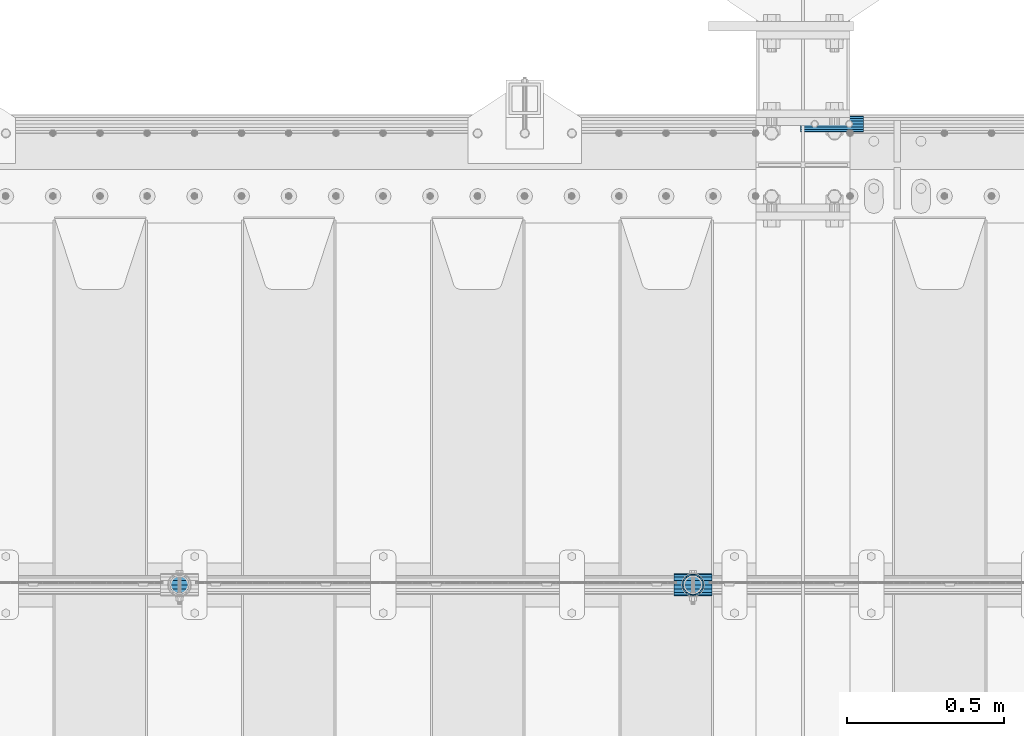
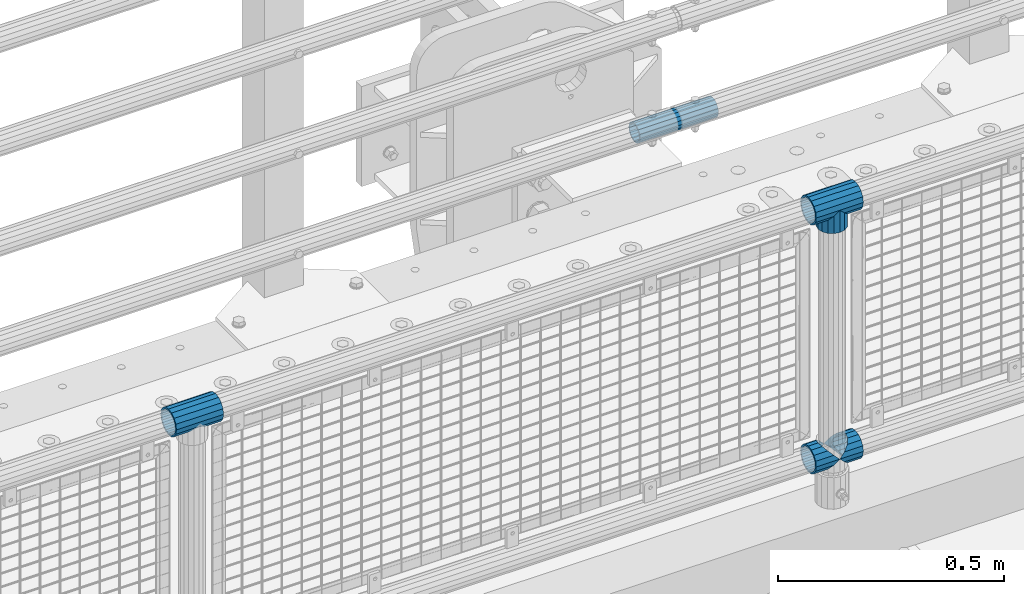
# One storey, part 169 of 270: 6 beams.
"""IFC2X3 building model written with IfcOpenShell, lengths in millimetres."""

from ifc_helpers import new_model, si_unit, frame, origin_with_axes, place, context, subcontext, project, spatial, faceted_brep, material, type_object, element, save


model = new_model("IFC2X3")

# Units and contexts
model_context = context("Model", 3, precision=1e-05, world=origin_with_axes())
body_context = subcontext(model_context, "Body", "Model", "MODEL_VIEW")
ifc_project = project(units=[si_unit("LENGTHUNIT", "METRE", prefix="MILLI"), si_unit("AREAUNIT", "SQUARE_METRE"), si_unit("VOLUMEUNIT", "CUBIC_METRE"), si_unit("MASSUNIT", "GRAM", prefix="KILO"), si_unit("TIMEUNIT", "SECOND"), si_unit("PLANEANGLEUNIT", "RADIAN"), si_unit("SOLIDANGLEUNIT", "STERADIAN"), si_unit("THERMODYNAMICTEMPERATUREUNIT", "DEGREE_CELSIUS"), si_unit("LUMINOUSINTENSITYUNIT", "LUMEN")], contexts=[model_context])

# Site, building, storey
site_placement = place(None, origin_with_axes())
site = spatial("IfcSite", under=ifc_project, at=site_placement, CompositionType="ELEMENT")
building_placement = place(site_placement, origin_with_axes())
building = spatial("IfcBuilding", under=site, at=building_placement, Name="Standard", CompositionType="ELEMENT")
storey_placement = place(building_placement, origin_with_axes())
storey = spatial("IfcBuildingStorey", under=building, at=storey_placement, Name="Undefined", CompositionType="ELEMENT", Elevation=0.0)

# Beams
ifc_material_1 = material(Name="Misc_Undefined")
beam_type_1 = type_object("IfcBeamType", PredefinedType="NOTDEFINED")
beam_1_placement = place(storey_placement, frame((13624.85, -16335.5, 298.17), z_axis=(0.0, 1.0, 0.0), x_axis=(1.0, 0.0, 0.0)))
element("IfcBeam", 1, at=beam_1_placement, inside=storey, type_object=beam_type_1, material=ifc_material_1, context=body_context, shape_type="Brep", body=[
    faceted_brep([(60.1499999999978, 0.0, -35.1499999999996), (46.698677352364, 13.4513226476329, -32.4743655677721), (46.698677352364, -13.4513226476329, -32.4743655677721), (33.0273231408937, 21.4606908090117, 21.4606908090118), (27.6756344322275, 26.8123795176776, 13.4513226476338), (27.6756344322275, 32.4743655677717, 13.4513226476338), (35.2951966412911, 24.8548033587072, 24.8548033587067), (35.2951966412911, 16.3810424080045, 24.8548033587067), (27.310256188277, 28.0397438117175, 11.6144421722802), (24.9999999999964, 30.35, 0.0), (24.9999999999964, 35.15, 0.0), (27.6756344322275, 26.8123795176775, -13.4513226476338), (27.6756344322275, 32.4743655677717, -13.4513226476338), (27.310256188277, 28.0397438117175, -11.6144421722802), (35.2951966412911, 16.3810424080045, -24.8548033587067), (35.2951966412911, 24.8548033587072, -24.8548033587067), (33.0273231408937, 21.4606908090117, -21.4606908090118), (40.0617968770166, 11.6144421722805, -28.0397438117179), (43.519339601633, 0.0, -30.3500000000004), (40.0617968770166, -11.6144421722805, -28.0397438117179), (35.2951966412911, -16.3810424080045, -24.8548033587067), (35.2951966412911, -24.8548033587072, -24.8548033587067), (33.0273231408937, -21.4606908090117, -21.4606908090118), (27.6756344322275, -26.8123795176776, -13.4513226476338), (27.6756344322275, -32.4743655677717, -13.4513226476338), (27.310256188277, -28.0397438117175, -11.6144421722802), (24.9999999999964, -30.35, 0.0), (24.9999999999964, -35.15, 0.0), (27.310256188277, -28.0397438117175, 11.6144421722802), (27.6756344322275, -26.8123795176775, 13.4513226476338), (27.6756344322275, -32.4743655677717, 13.4513226476338), (33.0273231408937, -21.4606908090117, 21.4606908090118), (35.2951966412911, -16.3810424080078, 24.8548033587067), (35.2951966412911, -24.8548033587072, 24.8548033587067), (60.1499999999978, 0.0, 35.1499999999996), (46.698677352364, -13.4513226476329, 32.4743655677721), (46.698677352364, 13.4513226476329, 32.4743655677721), (40.061796877013, -11.6144421722805, 28.0397438117179), (43.5193396016293, 0.0, 30.3500000000004), (40.061796877013, 11.6144421722805, 28.0397438117179), (0.0, -32.4743655677721, -13.4513226476338), (0.0, -24.8548033587067, -24.8548033587067), (0.0, -13.4513226476338, -32.4743655677703), (0.0, 0.0, -35.1499999999996), (0.0, 13.4513226476338, -32.4743655677703), (0.0, 24.8548033587067, -24.8548033587067), (0.0, 32.4743655677721, -13.4513226476338), (0.0, 35.1499999999996, 0.0), (0.0, 32.4743655677721, 13.4513226476338), (0.0, 24.8548033587067, 24.8548033587067), (0.0, 13.4513226476338, 32.4743655677703), (0.0, 0.0, 35.1499999999996), (0.0, -32.4743655677721, 13.4513226476338), (0.0, -35.1499999999996, 0.0), (0.0, -24.8548033587067, 24.8548033587067), (0.0, -13.4513226476338, 32.4743655677703), (0.0, -28.0397438117179, -11.614442172282), (0.0, -21.4606908090118, -21.46069080901), (0.0, -11.6144421722802, -28.0397438117179), (0.0, 0.0, -30.3499999999985), (0.0, 11.6144421722802, -28.0397438117179), (0.0, 21.4606908090118, -21.46069080901), (0.0, 28.0397438117179, -11.614442172282), (0.0, 30.3500000000004, 0.0), (0.0, 28.0397438117179, 11.614442172282), (0.0, 21.4606908090118, 21.46069080901), (0.0, 11.6144421722802, 28.0397438117179), (0.0, 0.0, 30.3499999999985), (0.0, -11.6144421722802, 28.0397438117179), (0.0, -21.4606908090118, 21.46069080901), (0.0, -28.0397438117179, 11.614442172282), (0.0, -30.3500000000004, 0.0)], [[[0, 1, 2]], [[3, 4, 5, 6, 7]], [[8, 9, 10, 5, 4]], [[11, 12, 10, 9, 13]], [[14, 15, 12, 11, 16]], [[2, 1, 15, 14, 17, 18, 19, 20, 21]], [[21, 20, 22, 23, 24]], [[24, 23, 25, 26, 27]], [[27, 26, 28, 29, 30]], [[30, 29, 31, 32, 33]], [[34, 35, 36]], [[33, 32, 37, 38, 39, 7, 6, 36, 35]], [[40, 41, 21, 24]], [[41, 42, 2, 21]], [[42, 43, 0, 2]], [[43, 44, 1, 0]], [[44, 45, 15, 1]], [[45, 46, 12, 15]], [[46, 47, 10, 12]], [[47, 48, 5, 10]], [[48, 49, 6, 5]], [[49, 50, 36, 6]], [[50, 51, 34, 36]], [[52, 53, 27, 30]], [[54, 52, 30, 33]], [[55, 54, 33, 35]], [[51, 55, 35, 34]], [[53, 40, 24, 27]], [[52, 54, 55, 51, 50, 49, 48, 47, 46, 45, 44, 43, 42, 41, 40, 53], [56, 57, 58, 59, 60, 61, 62, 63, 64, 65, 66, 67, 68, 69, 70, 71]], [[68, 67, 38, 37]], [[31, 69, 68, 37, 32]], [[28, 70, 69, 31, 29]], [[71, 70, 28, 26]], [[56, 71, 26, 25]], [[57, 56, 25, 23, 22]], [[58, 57, 22, 20, 19]], [[59, 58, 19, 18]], [[60, 59, 18, 17]], [[16, 61, 60, 17, 14]], [[13, 62, 61, 16, 11]], [[63, 62, 13, 9]], [[64, 63, 9, 8]], [[65, 64, 8, 4, 3]], [[66, 65, 3, 7, 39]], [[67, 66, 39, 38]]]),
])
beam_2_placement = place(storey_placement, frame((13685.0, -16335.5, 298.17), z_axis=(0.0, 1.0, 0.0), x_axis=(1.0, 0.0, 0.0)))
element("IfcBeam", 2, at=beam_2_placement, inside=storey, type_object=beam_type_1, material=ifc_material_1, context=body_context, shape_type="Brep", body=[
    faceted_brep([(13.4513226476338, 13.4513226476329, 32.4743655677721), (13.4513226476338, -13.4513226476329, 32.4743655677721), (0.0, 0.0, 35.1499999999996), (27.1226768591041, -21.4606908090117, -21.4606908090118), (24.8548033587067, -16.3810424080045, -24.8548033587067), (24.8548033587067, -24.8548033587072, -24.8548033587067), (32.4743655677703, -32.4743655677717, -13.4513226476338), (32.4743655677703, -26.8123795176776, -13.4513226476338), (0.0, 0.0, -35.1499999999996), (13.4513226476338, -13.4513226476329, -32.4743655677721), (13.4513226476338, 13.4513226476329, -32.4743655677721), (20.0882031229849, -11.6144421722805, -28.0397438117179), (16.6306603983721, 0.0, -30.3500000000004), (20.0882031229849, 11.6144421722805, -28.0397438117179), (24.8548033587067, 16.3810424080045, -24.8548033587067), (24.8548033587067, 24.8548033587072, -24.8548033587067), (27.1226768591041, 21.4606908090117, -21.4606908090118), (32.4743655677703, 26.8123795176775, -13.4513226476338), (32.4743655677703, 32.4743655677717, -13.4513226476338), (32.8397438117172, 28.0397438117175, -11.6144421722802), (35.1500000000015, 30.35, 0.0), (35.1500000000015, 35.1500000000003, 0.0), (32.8397438117208, 28.0397438117175, 11.6144421722802), (32.4743655677703, 26.8123795176776, 13.4513226476338), (32.4743655677703, 32.4743655677717, 13.4513226476338), (27.1226768591041, 21.4606908090117, 21.4606908090118), (24.8548033587067, 16.3810424080045, 24.8548033587067), (24.8548033587067, 24.8548033587072, 24.8548033587067), (20.0882031229812, 11.6144421722805, 28.0397438117179), (16.6306603983612, 0.0, 30.3500000000004), (20.0882031229812, -11.6144421722805, 28.0397438117179), (24.8548033587067, -16.3810424080045, 24.8548033587067), (24.8548033587067, -24.8548033587072, 24.8548033587067), (32.4743655677703, -26.8123795176775, 13.4513226476338), (32.4743655677703, -32.4743655677717, 13.4513226476338), (27.1226768591041, -21.4606908090117, 21.4606908090118), (35.1500000000015, -30.35, 0.0), (35.1500000000015, -35.15, 0.0), (32.8397438117208, -28.0397438117175, 11.6144421722802), (32.8397438117172, -28.0397438117175, -11.6144421722802), (60.1500000000015, -24.8548033587072, -24.8548033587067), (60.1500000000015, -32.4743655677717, -13.4513226476338), (60.1500000000015, -13.4513226476329, -32.4743655677721), (60.1499999999978, 0.0, -35.1499999999996), (60.1500000000015, 13.4513226476329, -32.4743655677721), (60.1500000000015, 24.8548033587072, -24.8548033587067), (60.1500000000015, 32.4743655677717, -13.4513226476338), (60.1500000000015, 35.15, 0.0), (60.1500000000015, 32.4743655677717, 13.4513226476338), (60.1500000000015, 24.8548033587072, 24.8548033587067), (60.1500000000015, 13.4513226476329, 32.4743655677721), (60.1499999999978, 0.0, 35.1499999999996), (60.1500000000015, -13.4513226476329, 32.4743655677721), (60.1500000000015, -24.8548033587072, 24.8548033587067), (60.1500000000015, -32.4743655677717, 13.4513226476338), (60.1500000000015, -35.15, 0.0), (60.1500000000015, -21.4606908090117, 21.4606908090118), (60.1500000000015, -11.6144421722805, 28.0397438117179), (60.1500000000015, 0.0, 30.3500000000004), (60.1500000000015, 11.6144421722805, 28.0397438117179), (60.1500000000015, 21.4606908090117, 21.4606908090118), (60.1500000000015, 28.0397438117175, 11.6144421722802), (60.1500000000015, 30.35, 0.0), (60.1500000000015, 28.0397438117175, -11.6144421722802), (60.1500000000015, 21.4606908090117, -21.4606908090118), (60.1500000000015, 11.6144421722805, -28.0397438117179), (60.1500000000015, 0.0, -30.3500000000004), (60.1500000000015, -11.6144421722805, -28.0397438117179), (60.1500000000015, -21.4606908090117, -21.4606908090118), (60.1500000000015, -28.0397438117175, -11.6144421722802), (60.1500000000015, -30.35, 0.0), (60.1500000000015, -28.0397438117175, 11.6144421722802)], [[[0, 1, 2]], [[3, 4, 5, 6, 7]], [[8, 9, 10]], [[10, 9, 5, 4, 11, 12, 13, 14, 15]], [[15, 14, 16, 17, 18]], [[18, 17, 19, 20, 21]], [[21, 20, 22, 23, 24]], [[24, 23, 25, 26, 27]], [[27, 26, 28, 29, 30, 31, 32, 1, 0]], [[33, 34, 32, 31, 35]], [[36, 37, 34, 33, 38]], [[39, 7, 6, 37, 36]], [[40, 41, 6, 5]], [[42, 40, 5, 9]], [[43, 42, 9, 8]], [[44, 43, 8, 10]], [[45, 44, 10, 15]], [[46, 45, 15, 18]], [[47, 46, 18, 21]], [[48, 47, 21, 24]], [[49, 48, 24, 27]], [[50, 49, 27, 0]], [[51, 50, 0, 2]], [[52, 51, 2, 1]], [[53, 52, 1, 32]], [[54, 53, 32, 34]], [[55, 54, 34, 37]], [[41, 55, 37, 6]], [[40, 42, 43, 44, 45, 46, 47, 48, 49, 50, 51, 52, 53, 54, 55, 41], [56, 57, 58, 59, 60, 61, 62, 63, 64, 65, 66, 67, 68, 69, 70, 71]], [[71, 70, 36, 38]], [[35, 56, 71, 38, 33]], [[30, 57, 56, 35, 31]], [[58, 57, 30, 29]], [[59, 58, 29, 28]], [[60, 59, 28, 26, 25]], [[61, 60, 25, 23, 22]], [[62, 61, 22, 20]], [[63, 62, 20, 19]], [[16, 64, 63, 19, 17]], [[13, 65, 64, 16, 14]], [[66, 65, 13, 12]], [[67, 66, 12, 11]], [[68, 67, 11, 4, 3]], [[69, 68, 3, 7, 39]], [[70, 69, 39, 36]]]),
])
beam_3_placement = place(storey_placement, frame((13685.0, -16335.5, 969.849999999999), z_axis=(0.0, 1.0, 0.0), x_axis=(0.0, 0.0, -1.0)))
element("IfcBeam", 3, at=beam_3_placement, inside=storey, type_object=beam_type_1, material=ifc_material_1, context=body_context, shape_type="Brep", body=[
    faceted_brep([(13.4513226476338, 13.4513226476329, 32.4743655677721), (13.4513226476338, -13.4513226476329, 32.4743655677721), (0.0, 0.0, 35.1499999999996), (27.1226768591041, -21.4606908090117, -21.4606908090118), (24.8548033587067, -16.3810424080045, -24.8548033587067), (24.8548033587067, -24.8548033587072, -24.8548033587067), (32.4743655677703, -32.4743655677717, -13.4513226476338), (32.4743655677703, -26.8123795176776, -13.4513226476338), (0.0, 0.0, -35.1499999999996), (13.4513226476338, -13.4513226476329, -32.4743655677721), (13.4513226476338, 13.4513226476329, -32.4743655677721), (20.0882031229849, -11.6144421722805, -28.0397438117179), (16.6306603983721, 0.0, -30.3500000000004), (20.0882031229849, 11.6144421722805, -28.0397438117179), (24.8548033587067, 16.3810424080045, -24.8548033587067), (24.8548033587067, 24.8548033587072, -24.8548033587067), (27.1226768591041, 21.4606908090117, -21.4606908090118), (32.4743655677703, 26.8123795176775, -13.4513226476338), (32.4743655677703, 32.4743655677717, -13.4513226476338), (32.8397438117172, 28.0397438117175, -11.6144421722802), (35.1500000000015, 30.35, 0.0), (35.1500000000015, 35.1500000000003, 0.0), (32.8397438117208, 28.0397438117175, 11.6144421722802), (32.4743655677703, 26.8123795176776, 13.4513226476338), (32.4743655677703, 32.4743655677717, 13.4513226476338), (27.1226768591041, 21.4606908090117, 21.4606908090118), (24.8548033587067, 16.3810424080045, 24.8548033587067), (24.8548033587067, 24.8548033587072, 24.8548033587067), (20.0882031229812, 11.6144421722805, 28.0397438117179), (16.6306603983612, 0.0, 30.3500000000004), (20.0882031229812, -11.6144421722805, 28.0397438117179), (24.8548033587067, -16.3810424080045, 24.8548033587067), (24.8548033587067, -24.8548033587072, 24.8548033587067), (32.4743655677703, -26.8123795176775, 13.4513226476338), (32.4743655677703, -32.4743655677717, 13.4513226476338), (27.1226768591041, -21.4606908090117, 21.4606908090118), (35.1500000000015, -30.35, 0.0), (35.1500000000015, -35.15, 0.0), (32.8397438117208, -28.0397438117175, 11.6144421722802), (32.8397438117172, -28.0397438117175, -11.6144421722802), (60.1500000000015, -24.8548033587072, -24.8548033587067), (60.1500000000015, -32.4743655677717, -13.4513226476338), (60.1500000000015, -13.4513226476329, -32.4743655677721), (60.1499999999978, 0.0, -35.1499999999996), (60.1500000000015, 13.4513226476329, -32.4743655677721), (60.1500000000015, 24.8548033587072, -24.8548033587067), (60.1500000000015, 32.4743655677717, -13.4513226476338), (60.1500000000015, 35.15, 0.0), (60.1500000000015, 32.4743655677717, 13.4513226476338), (60.1500000000015, 24.8548033587072, 24.8548033587067), (60.1500000000015, 13.4513226476329, 32.4743655677721), (60.1499999999978, 0.0, 35.1499999999996), (60.1500000000015, -13.4513226476329, 32.4743655677721), (60.1500000000015, -24.8548033587072, 24.8548033587067), (60.1500000000015, -32.4743655677717, 13.4513226476338), (60.1500000000015, -35.15, 0.0), (60.1500000000015, -21.4606908090117, 21.4606908090118), (60.1500000000015, -11.6144421722805, 28.0397438117179), (60.1500000000015, 0.0, 30.3500000000004), (60.1500000000015, 11.6144421722805, 28.0397438117179), (60.1500000000015, 21.4606908090117, 21.4606908090118), (60.1500000000015, 28.0397438117175, 11.6144421722802), (60.1500000000015, 30.35, 0.0), (60.1500000000015, 28.0397438117175, -11.6144421722802), (60.1500000000015, 21.4606908090117, -21.4606908090118), (60.1500000000015, 11.6144421722805, -28.0397438117179), (60.1500000000015, 0.0, -30.3500000000004), (60.1500000000015, -11.6144421722805, -28.0397438117179), (60.1500000000015, -21.4606908090117, -21.4606908090118), (60.1500000000015, -28.0397438117175, -11.6144421722802), (60.1500000000015, -30.35, 0.0), (60.1500000000015, -28.0397438117175, 11.6144421722802)], [[[0, 1, 2]], [[3, 4, 5, 6, 7]], [[8, 9, 10]], [[10, 9, 5, 4, 11, 12, 13, 14, 15]], [[15, 14, 16, 17, 18]], [[18, 17, 19, 20, 21]], [[21, 20, 22, 23, 24]], [[24, 23, 25, 26, 27]], [[27, 26, 28, 29, 30, 31, 32, 1, 0]], [[33, 34, 32, 31, 35]], [[36, 37, 34, 33, 38]], [[39, 7, 6, 37, 36]], [[40, 41, 6, 5]], [[42, 40, 5, 9]], [[43, 42, 9, 8]], [[44, 43, 8, 10]], [[45, 44, 10, 15]], [[46, 45, 15, 18]], [[47, 46, 18, 21]], [[48, 47, 21, 24]], [[49, 48, 24, 27]], [[50, 49, 27, 0]], [[51, 50, 0, 2]], [[52, 51, 2, 1]], [[53, 52, 1, 32]], [[54, 53, 32, 34]], [[55, 54, 34, 37]], [[41, 55, 37, 6]], [[40, 42, 43, 44, 45, 46, 47, 48, 49, 50, 51, 52, 53, 54, 55, 41], [56, 57, 58, 59, 60, 61, 62, 63, 64, 65, 66, 67, 68, 69, 70, 71]], [[71, 70, 36, 38]], [[35, 56, 71, 38, 33]], [[30, 57, 56, 35, 31]], [[58, 57, 30, 29]], [[59, 58, 29, 28]], [[60, 59, 28, 26, 25]], [[61, 60, 25, 23, 22]], [[62, 61, 22, 20]], [[63, 62, 20, 19]], [[16, 64, 63, 19, 17]], [[13, 65, 64, 16, 14]], [[66, 65, 13, 12]], [[67, 66, 12, 11]], [[68, 67, 11, 4, 3]], [[69, 68, 3, 7, 39]], [[70, 69, 39, 36]]]),
])
beam_4_placement = place(storey_placement, frame((13624.85, -16335.5, 969.849999999999), z_axis=(0.0, 0.0, 1.0), x_axis=(1.0, 0.0, 0.0)))
element("IfcBeam", 4, at=beam_4_placement, inside=storey, type_object=beam_type_1, material=ifc_material_1, context=body_context, shape_type="Brep", body=[
    faceted_brep([(88.1897438117176, -11.6144421722802, -28.0397438117176), (88.1897438117176, -11.6144421722802, -32.839743811718), (86.9623795176758, -13.4513226476338, -32.4743655677718), (81.6106908090119, -21.4606908090118, -27.1226768591079), (81.6106908090119, -21.4606908090118, -21.4606908090117), (76.5310424080044, -24.8548033587067, -24.8548033587072), (71.7644421722807, -28.0397438117179, -20.0882031229829), (71.7644421722807, -28.0397438117179, -11.6144421722805), (60.1500000000001, -30.3500000000004, -16.6306603983638), (60.1500000000015, -30.35, 0.0), (48.5355578277195, -28.0397438117179, -20.0882031229829), (48.5355578277195, -28.0397438117179, -11.6144421722805), (43.7689575919958, -24.8548033587067, -24.8548033587072), (38.6893091909883, -21.4606908090118, -27.1226768591079), (38.6893091909883, -21.4606908090118, -21.4606908090117), (33.3376204823235, -13.4513226476338, -32.4743655677718), (32.1102561882826, -11.6144421722802, -32.839743811718), (32.1102561882826, -11.6144421722802, -28.0397438117176), (29.8000000000002, 0.0, -35.15), (29.8000000000002, 0.0, -30.35), (32.1102561882826, 11.6144421722802, -32.839743811718), (32.1102561882826, 11.6144421722802, -28.0397438117176), (33.3376204823244, 13.4513226476338, -32.4743655677718), (38.6893091909883, 21.4606908090118, -27.1226768591056), (38.6893091909883, 21.4606908090118, -21.4606908090117), (43.7689575919958, 24.8548033587067, -24.8548033587072), (48.5355578277195, 28.0397438117179, -20.0882031229829), (48.5355578277195, 28.0397438117179, -11.6144421722805), (60.1500000000001, 30.3500000000004, -16.6306603983638), (60.1500000000015, 30.35, 0.0), (71.7644421722807, 28.0397438117179, -20.0882031229829), (71.7644421722807, 28.0397438117179, -11.6144421722805), (76.5310424080044, 24.8548033587067, -24.8548033587072), (81.6106908090119, 21.4606908090118, -27.1226768591056), (81.6106908090119, 21.4606908090118, -21.4606908090117), (86.9623795176776, 13.4513226476338, -32.4743655677718), (88.1897438117176, 11.6144421722802, -32.839743811718), (88.1897438117176, 11.6144421722802, -28.0397438117176), (90.5, 0.0, -35.15), (90.5, 0.0, -30.35), (0.0, -21.4606908090118, -21.46069080901), (0.0, -28.0397438117179, -11.614442172282), (0.0, -11.6144421722802, -28.0397438117179), (0.0, 0.0, -30.3499999999985), (0.0, 11.6144421722802, -28.0397438117179), (0.0, 21.4606908090118, -21.46069080901), (0.0, 28.0397438117179, -11.614442172282), (0.0, 30.3500000000004, 0.0), (0.0, 32.4743655677721, -13.4513226476338), (0.0, 35.1499999999996, 0.0), (120.3, 35.1499999999996, 0.0), (120.3, 32.4743655677721, -13.4513226476329), (0.0, 32.4743655677721, 13.4513226476338), (120.3, 32.4743655677721, 13.4513226476329), (0.0, 24.8548033587067, 24.8548033587067), (120.3, 24.8548033587067, 24.8548033587072), (0.0, 13.4513226476338, 32.4743655677703), (120.3, 13.4513226476338, 32.4743655677718), (0.0, 0.0, 35.1499999999996), (120.3, 0.0, 35.15), (0.0, -13.4513226476338, 32.4743655677703), (120.3, -13.4513226476338, 32.4743655677718), (0.0, -24.8548033587067, 24.8548033587067), (120.3, -24.8548033587067, 24.8548033587072), (0.0, -32.4743655677721, 13.4513226476338), (120.3, -32.4743655677721, 13.4513226476329), (0.0, -35.1499999999996, 0.0), (120.3, -35.1499999999996, 0.0), (0.0, -32.4743655677721, -13.4513226476338), (120.3, -32.4743655677721, -13.4513226476329), (0.0, 24.8548033587067, -24.8548033587067), (0.0, 13.4513226476338, -32.4743655677703), (0.0, 0.0, -35.1499999999996), (0.0, -13.4513226476338, -32.4743655677703), (0.0, -24.8548033587067, -24.8548033587067), (0.0, 28.0397438117179, 11.614442172282), (0.0, 21.4606908090118, 21.46069080901), (0.0, 11.6144421722802, 28.0397438117179), (0.0, 0.0, 30.3499999999985), (0.0, -11.6144421722802, 28.0397438117179), (0.0, -21.4606908090118, 21.46069080901), (0.0, -28.0397438117179, 11.614442172282), (0.0, -30.3500000000004, 0.0), (120.3, -30.3500000000004, 0.0), (120.3, -28.0397438117179, -11.6144421722805), (120.3, -21.4606908090118, -21.4606908090117), (120.3, -11.6144421722802, -28.0397438117176), (120.3, 0.0, -30.35), (120.3, 21.4606908090118, -21.4606908090117), (120.3, 28.0397438117179, -11.6144421722805), (120.3, 11.6144421722802, -28.0397438117176), (120.3, 30.3500000000004, 0.0), (120.3, 28.0397438117179, 11.6144421722805), (120.3, 21.4606908090118, 21.4606908090117), (120.3, 11.6144421722802, 28.0397438117176), (120.3, 0.0, 30.35), (120.3, -11.6144421722802, 28.0397438117176), (120.3, -21.4606908090118, 21.4606908090117), (120.3, -28.0397438117179, 11.6144421722805), (120.3, -24.8548033587067, -24.8548033587072), (120.3, -13.4513226476338, -32.4743655677718), (120.3, 0.0, -35.15), (120.3, 13.4513226476338, -32.4743655677718), (120.3, 24.8548033587067, -24.8548033587072)], [[[0, 1, 2, 3, 4]], [[4, 3, 5, 6, 7]], [[7, 6, 8, 9]], [[9, 8, 10, 11]], [[11, 10, 12, 13, 14]], [[14, 13, 15, 16, 17]], [[17, 16, 18, 19]], [[19, 18, 20, 21]], [[21, 20, 22, 23, 24]], [[24, 23, 25, 26, 27]], [[27, 26, 28, 29]], [[29, 28, 30, 31]], [[31, 30, 32, 33, 34]], [[34, 33, 35, 36, 37]], [[37, 36, 38, 39]], [[39, 38, 1, 0]], [[40, 41, 11, 14]], [[42, 40, 14, 17]], [[43, 42, 17, 19]], [[44, 43, 19, 21]], [[45, 44, 21, 24]], [[46, 45, 24, 27]], [[47, 46, 27, 29]], [[48, 49, 50, 51]], [[49, 52, 53, 50]], [[52, 54, 55, 53]], [[54, 56, 57, 55]], [[56, 58, 59, 57]], [[58, 60, 61, 59]], [[60, 62, 63, 61]], [[62, 64, 65, 63]], [[64, 66, 67, 65]], [[66, 68, 69, 67]], [[64, 62, 60, 58, 56, 54, 52, 49, 48, 70, 71, 72, 73, 74, 68, 66], [41, 40, 42, 43, 44, 45, 46, 47, 75, 76, 77, 78, 79, 80, 81, 82]], [[41, 82, 9, 11]], [[83, 84, 7, 9]], [[84, 85, 4, 7]], [[85, 86, 0, 4]], [[86, 87, 39, 0]], [[88, 89, 31, 34]], [[90, 88, 34, 37]], [[87, 90, 37, 39]], [[89, 91, 29, 31]], [[75, 47, 29, 91, 92]], [[76, 75, 92, 93]], [[77, 76, 93, 94]], [[78, 77, 94, 95]], [[79, 78, 95, 96]], [[80, 79, 96, 97]], [[81, 80, 97, 98]], [[9, 82, 81, 98, 83]], [[99, 100, 101, 102, 103, 51, 50, 53, 55, 57, 59, 61, 63, 65, 67, 69], [97, 96, 95, 94, 93, 92, 91, 89, 88, 90, 87, 86, 85, 84, 83, 98]], [[35, 102, 101, 38, 36]], [[32, 103, 102, 35, 33]], [[28, 26, 25, 70, 48, 51, 103, 32, 30]], [[22, 71, 70, 25, 23]], [[18, 72, 71, 22, 20]], [[73, 72, 18, 16, 15]], [[74, 73, 15, 13, 12]], [[99, 69, 68, 74, 12, 10, 8, 6, 5]], [[100, 99, 5, 3, 2]], [[101, 100, 2, 1, 38]]]),
])
beam_5_placement = place(storey_placement, frame((11991.85, -16335.5, 969.849999999999), z_axis=(0.0, 0.0, 1.0), x_axis=(1.0, 0.0, 0.0)))
element("IfcBeam", 5, at=beam_5_placement, inside=storey, type_object=beam_type_1, material=ifc_material_1, context=body_context, shape_type="Brep", body=[
    faceted_brep([(88.1897438117176, -11.6144421722802, -28.0397438117176), (88.1897438117176, -11.6144421722802, -32.839743811718), (86.9623795176758, -13.4513226476338, -32.4743655677718), (81.6106908090119, -21.4606908090118, -27.1226768591079), (81.6106908090119, -21.4606908090118, -21.4606908090117), (76.5310424080044, -24.8548033587067, -24.8548033587072), (71.7644421722807, -28.0397438117179, -20.0882031229829), (71.7644421722807, -28.0397438117179, -11.6144421722805), (60.1500000000001, -30.3500000000004, -16.6306603983638), (60.1500000000015, -30.35, 0.0), (48.5355578277195, -28.0397438117179, -20.0882031229829), (48.5355578277195, -28.0397438117179, -11.6144421722805), (43.7689575919958, -24.8548033587067, -24.8548033587072), (38.6893091909883, -21.4606908090118, -27.1226768591079), (38.6893091909883, -21.4606908090118, -21.4606908090117), (33.3376204823235, -13.4513226476338, -32.4743655677718), (32.1102561882826, -11.6144421722802, -32.839743811718), (32.1102561882826, -11.6144421722802, -28.0397438117176), (29.8000000000002, 0.0, -35.15), (29.8000000000002, 0.0, -30.35), (32.1102561882826, 11.6144421722802, -32.839743811718), (32.1102561882826, 11.6144421722802, -28.0397438117176), (33.3376204823244, 13.4513226476338, -32.4743655677718), (38.6893091909883, 21.4606908090118, -27.1226768591056), (38.6893091909883, 21.4606908090118, -21.4606908090117), (43.7689575919958, 24.8548033587067, -24.8548033587072), (48.5355578277195, 28.0397438117179, -20.0882031229829), (48.5355578277195, 28.0397438117179, -11.6144421722805), (60.1500000000001, 30.3500000000004, -16.6306603983638), (60.1500000000015, 30.35, 0.0), (71.7644421722807, 28.0397438117179, -20.0882031229829), (71.7644421722807, 28.0397438117179, -11.6144421722805), (76.5310424080044, 24.8548033587067, -24.8548033587072), (81.6106908090119, 21.4606908090118, -27.1226768591056), (81.6106908090119, 21.4606908090118, -21.4606908090117), (86.9623795176776, 13.4513226476338, -32.4743655677718), (88.1897438117176, 11.6144421722802, -32.839743811718), (88.1897438117176, 11.6144421722802, -28.0397438117176), (90.5, 0.0, -35.15), (90.5, 0.0, -30.35), (0.0, -21.4606908090118, -21.46069080901), (0.0, -28.0397438117179, -11.614442172282), (0.0, -11.6144421722802, -28.0397438117179), (0.0, 0.0, -30.3499999999985), (0.0, 11.6144421722802, -28.0397438117179), (0.0, 21.4606908090118, -21.46069080901), (0.0, 28.0397438117179, -11.614442172282), (0.0, 30.3500000000004, 0.0), (0.0, 32.4743655677721, -13.4513226476338), (0.0, 35.1499999999996, 0.0), (120.3, 35.1499999999996, 0.0), (120.3, 32.4743655677721, -13.4513226476329), (0.0, 32.4743655677721, 13.4513226476338), (120.3, 32.4743655677721, 13.4513226476329), (0.0, 24.8548033587067, 24.8548033587067), (120.3, 24.8548033587067, 24.8548033587072), (0.0, 13.4513226476338, 32.4743655677703), (120.3, 13.4513226476338, 32.4743655677718), (0.0, 0.0, 35.1499999999996), (120.3, 0.0, 35.15), (0.0, -13.4513226476338, 32.4743655677703), (120.3, -13.4513226476338, 32.4743655677718), (0.0, -24.8548033587067, 24.8548033587067), (120.3, -24.8548033587067, 24.8548033587072), (0.0, -32.4743655677721, 13.4513226476338), (120.3, -32.4743655677721, 13.4513226476329), (0.0, -35.1499999999996, 0.0), (120.3, -35.1499999999996, 0.0), (0.0, -32.4743655677721, -13.4513226476338), (120.3, -32.4743655677721, -13.4513226476329), (0.0, 24.8548033587067, -24.8548033587067), (0.0, 13.4513226476338, -32.4743655677703), (0.0, 0.0, -35.1499999999996), (0.0, -13.4513226476338, -32.4743655677703), (0.0, -24.8548033587067, -24.8548033587067), (0.0, 28.0397438117179, 11.614442172282), (0.0, 21.4606908090118, 21.46069080901), (0.0, 11.6144421722802, 28.0397438117179), (0.0, 0.0, 30.3499999999985), (0.0, -11.6144421722802, 28.0397438117179), (0.0, -21.4606908090118, 21.46069080901), (0.0, -28.0397438117179, 11.614442172282), (0.0, -30.3500000000004, 0.0), (120.3, -30.3500000000004, 0.0), (120.3, -28.0397438117179, -11.6144421722805), (120.3, -21.4606908090118, -21.4606908090117), (120.3, -11.6144421722802, -28.0397438117176), (120.3, 0.0, -30.35), (120.3, 21.4606908090118, -21.4606908090117), (120.3, 28.0397438117179, -11.6144421722805), (120.3, 11.6144421722802, -28.0397438117176), (120.3, 30.3500000000004, 0.0), (120.3, 28.0397438117179, 11.6144421722805), (120.3, 21.4606908090118, 21.4606908090117), (120.3, 11.6144421722802, 28.0397438117176), (120.3, 0.0, 30.35), (120.3, -11.6144421722802, 28.0397438117176), (120.3, -21.4606908090118, 21.4606908090117), (120.3, -28.0397438117179, 11.6144421722805), (120.3, -24.8548033587067, -24.8548033587072), (120.3, -13.4513226476338, -32.4743655677718), (120.3, 0.0, -35.15), (120.3, 13.4513226476338, -32.4743655677718), (120.3, 24.8548033587067, -24.8548033587072)], [[[0, 1, 2, 3, 4]], [[4, 3, 5, 6, 7]], [[7, 6, 8, 9]], [[9, 8, 10, 11]], [[11, 10, 12, 13, 14]], [[14, 13, 15, 16, 17]], [[17, 16, 18, 19]], [[19, 18, 20, 21]], [[21, 20, 22, 23, 24]], [[24, 23, 25, 26, 27]], [[27, 26, 28, 29]], [[29, 28, 30, 31]], [[31, 30, 32, 33, 34]], [[34, 33, 35, 36, 37]], [[37, 36, 38, 39]], [[39, 38, 1, 0]], [[40, 41, 11, 14]], [[42, 40, 14, 17]], [[43, 42, 17, 19]], [[44, 43, 19, 21]], [[45, 44, 21, 24]], [[46, 45, 24, 27]], [[47, 46, 27, 29]], [[48, 49, 50, 51]], [[49, 52, 53, 50]], [[52, 54, 55, 53]], [[54, 56, 57, 55]], [[56, 58, 59, 57]], [[58, 60, 61, 59]], [[60, 62, 63, 61]], [[62, 64, 65, 63]], [[64, 66, 67, 65]], [[66, 68, 69, 67]], [[64, 62, 60, 58, 56, 54, 52, 49, 48, 70, 71, 72, 73, 74, 68, 66], [41, 40, 42, 43, 44, 45, 46, 47, 75, 76, 77, 78, 79, 80, 81, 82]], [[41, 82, 9, 11]], [[83, 84, 7, 9]], [[84, 85, 4, 7]], [[85, 86, 0, 4]], [[86, 87, 39, 0]], [[88, 89, 31, 34]], [[90, 88, 34, 37]], [[87, 90, 37, 39]], [[89, 91, 29, 31]], [[75, 47, 29, 91, 92]], [[76, 75, 92, 93]], [[77, 76, 93, 94]], [[78, 77, 94, 95]], [[79, 78, 95, 96]], [[80, 79, 96, 97]], [[81, 80, 97, 98]], [[9, 82, 81, 98, 83]], [[99, 100, 101, 102, 103, 51, 50, 53, 55, 57, 59, 61, 63, 65, 67, 69], [97, 96, 95, 94, 93, 92, 91, 89, 88, 90, 87, 86, 85, 84, 83, 98]], [[35, 102, 101, 38, 36]], [[32, 103, 102, 35, 33]], [[28, 26, 25, 70, 48, 51, 103, 32, 30]], [[22, 71, 70, 25, 23]], [[18, 72, 71, 22, 20]], [[73, 72, 18, 16, 15]], [[74, 73, 15, 13, 12]], [[99, 69, 68, 74, 12, 10, 8, 6, 5]], [[100, 99, 5, 3, 2]], [[101, 100, 2, 1, 38]]]),
])
ifc_material_2 = material()
beam_type_2 = type_object("IfcBeamType", PredefinedType="NOTDEFINED")
beam_6_placement = place(storey_placement, frame((14026.9975029999, -14870.1499999996, 149.849999999726), z_axis=(0.0, 0.0, 1.0), x_axis=(1.0, 0.0, 0.0)))
element("IfcBeam", 6, at=beam_6_placement, inside=storey, type_object=beam_type_2, material=ifc_material_2, context=body_context, shape_type="Brep", body=[
    faceted_brep([(0.0, -21.8999999999996, 0.0), (0.0, -20.232961761998, 8.38076716879547), (200.0, -20.232961761998, 8.38076716879547), (200.0, -21.8999999999996, 0.0), (0.0, -15.4856385079856, 15.4856385079854), (200.0, -15.4856385079856, 15.4856385079854), (0.0, -8.3807671687955, 20.2329617619972), (200.0, -8.3807671687955, 20.2329617619972), (0.0, 0.0, 21.9), (200.0, 0.0, 21.9), (0.0, 8.3807671687955, 20.2329617619972), (200.0, 8.3807671687955, 20.2329617619972), (0.0, 15.4856385079856, 15.4856385079854), (200.0, 15.4856385079856, 15.4856385079854), (0.0, 20.232961761998, 8.38076716879547), (200.0, 20.232961761998, 8.38076716879547), (0.0, 21.8999999999996, 0.0), (200.0, 21.8999999999996, 0.0), (0.0, 20.232961761998, -8.38076716879547), (200.0, 20.232961761998, -8.38076716879547), (0.0, 15.4856385079856, -15.4856385079854), (200.0, 15.4856385079856, -15.4856385079854), (0.0, 8.3807671687955, -20.2329617619972), (200.0, 8.3807671687955, -20.2329617619972), (0.0, 0.0, -21.9), (200.0, 0.0, -21.9), (0.0, -8.3807671687955, -20.2329617619972), (200.0, -8.3807671687955, -20.2329617619972), (0.0, -15.4856385079856, -15.4856385079854), (200.0, -15.4856385079856, -15.4856385079854), (0.0, -20.232961761998, -8.38076716879547), (200.0, -20.232961761998, -8.38076716879547), (0.0, -25.5, 0.0), (0.0, -23.5589280790373, -9.7584275253098), (200.0, -23.5589280790373, -9.7584275253098), (200.0, -25.5, 0.0), (0.0, -18.0312229202573, -18.031222920257), (200.0, -18.0312229202573, -18.031222920257), (0.0, -9.75842752531025, -23.5589280790378), (200.0, -9.75842752531025, -23.5589280790378), (0.0, 0.0, -25.5), (200.0, 0.0, -25.5), (0.0, 9.75842752531025, -23.5589280790378), (200.0, 9.75842752531025, -23.5589280790378), (0.0, 18.0312229202573, -18.031222920257), (200.0, 18.0312229202573, -18.031222920257), (0.0, 23.5589280790373, -9.7584275253098), (200.0, 23.5589280790373, -9.7584275253098), (0.0, 25.5, 0.0), (200.0, 25.5, 0.0), (0.0, 23.5589280790373, 9.7584275253098), (200.0, 23.5589280790373, 9.7584275253098), (0.0, 18.0312229202573, 18.031222920257), (200.0, 18.0312229202573, 18.031222920257), (0.0, 9.75842752531025, 23.5589280790378), (200.0, 9.75842752531025, 23.5589280790378), (0.0, 0.0, 25.5), (200.0, 0.0, 25.5), (0.0, -9.75842752531025, 23.5589280790378), (200.0, -9.75842752531025, 23.5589280790378), (0.0, -18.0312229202573, 18.031222920257), (200.0, -18.0312229202573, 18.031222920257), (0.0, -23.5589280790373, 9.7584275253098), (200.0, -23.5589280790373, 9.7584275253098)], [[[0, 1, 2, 3]], [[1, 4, 5, 2]], [[4, 6, 7, 5]], [[6, 8, 9, 7]], [[8, 10, 11, 9]], [[10, 12, 13, 11]], [[12, 14, 15, 13]], [[14, 16, 17, 15]], [[16, 18, 19, 17]], [[18, 20, 21, 19]], [[20, 22, 23, 21]], [[22, 24, 25, 23]], [[24, 26, 27, 25]], [[26, 28, 29, 27]], [[28, 30, 31, 29]], [[30, 0, 3, 31]], [[32, 33, 34, 35]], [[33, 36, 37, 34]], [[36, 38, 39, 37]], [[38, 40, 41, 39]], [[40, 42, 43, 41]], [[42, 44, 45, 43]], [[44, 46, 47, 45]], [[46, 48, 49, 47]], [[48, 50, 51, 49]], [[50, 52, 53, 51]], [[52, 54, 55, 53]], [[54, 56, 57, 55]], [[56, 58, 59, 57]], [[58, 60, 61, 59]], [[60, 62, 63, 61]], [[62, 32, 35, 63]], [[37, 39, 41, 43, 45, 47, 49, 51, 53, 55, 57, 59, 61, 63, 35, 34], [5, 7, 9, 11, 13, 15, 17, 19, 21, 23, 25, 27, 29, 31, 3, 2]], [[62, 60, 58, 56, 54, 52, 50, 48, 46, 44, 42, 40, 38, 36, 33, 32], [30, 28, 26, 24, 22, 20, 18, 16, 14, 12, 10, 8, 6, 4, 1, 0]]]),
])

save(model, "model.ifc")
